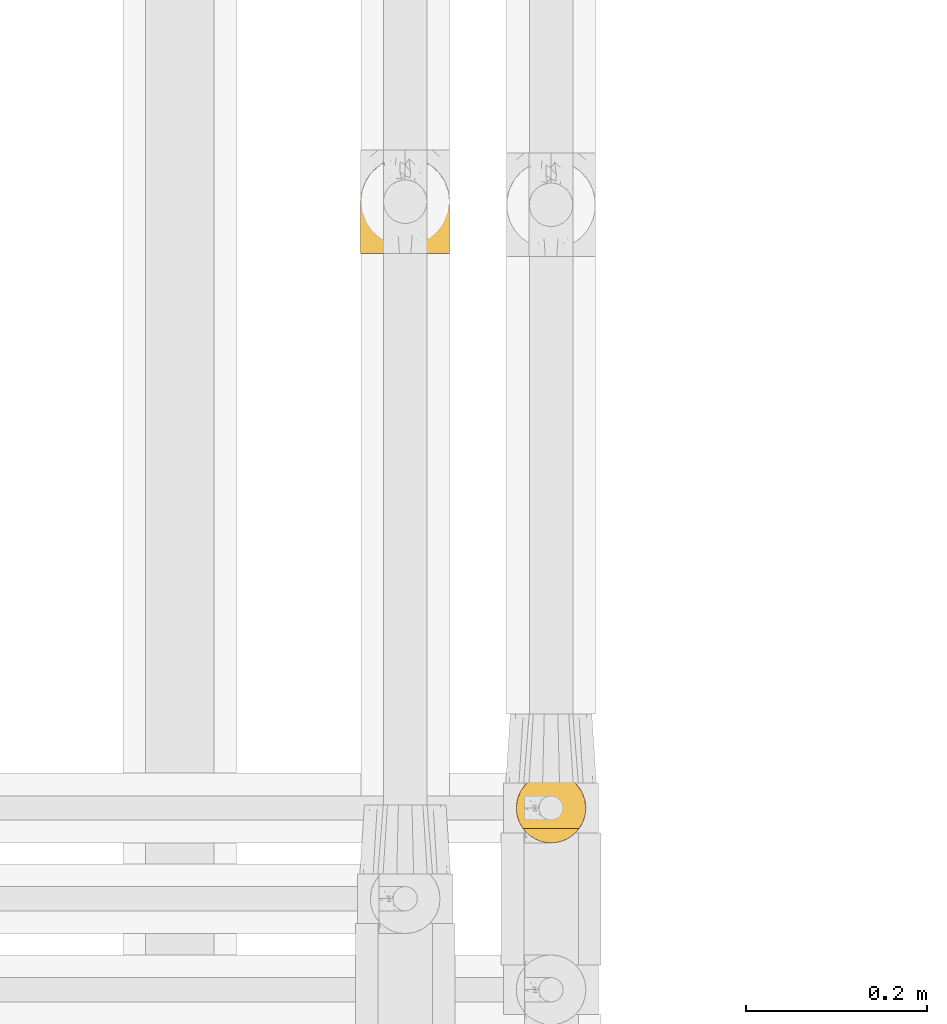
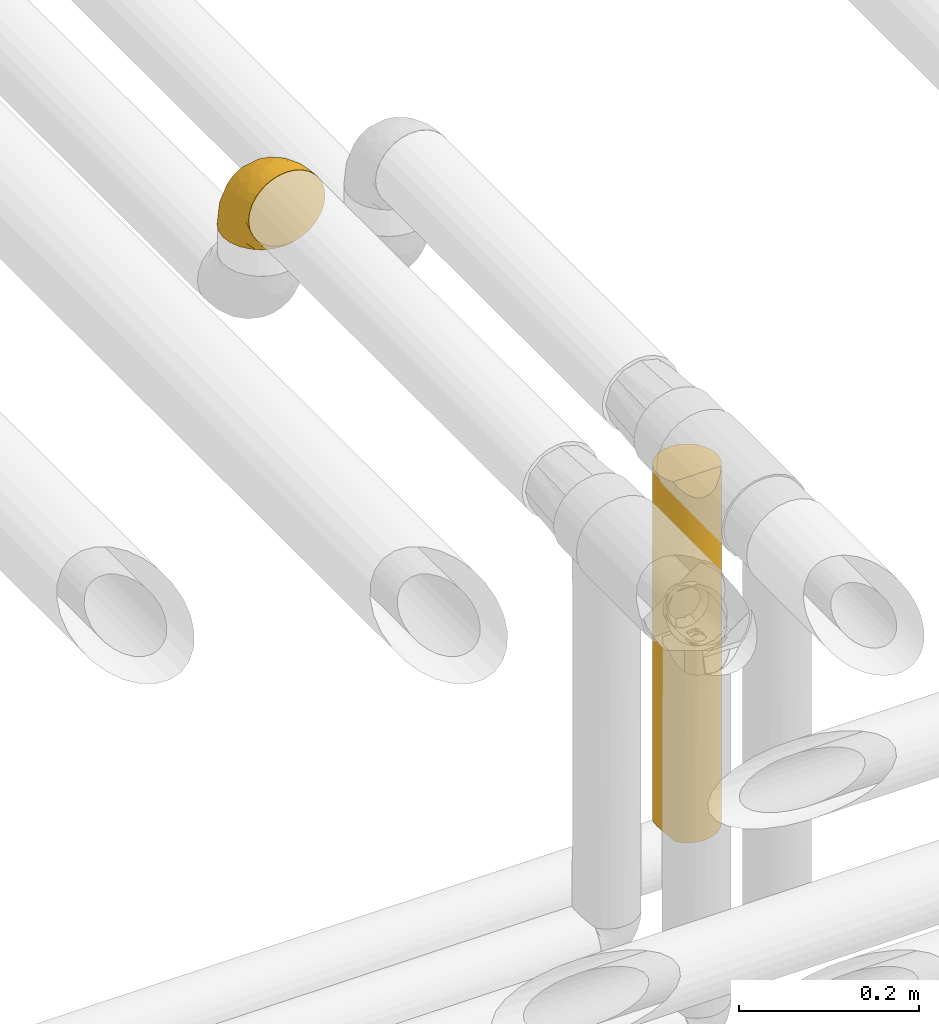
# One storey, part 345 of 827: 2 coverings.
"""IFC2X3 building model written with IfcOpenShell, lengths in millimetres."""

from ifc_helpers import new_model, entity, si_unit, converted_unit, derived_unit, direction, frame, origin, place, context, subcontext, project, spatial, faceted_brep, element, save


model = new_model("IFC2X3")

# Units and contexts
model_context = context("Model", 3, precision=0.01, world=origin(), true_north=direction((6.12303176911189e-17, 1.0)))
body_context = subcontext(model_context, "Body", "Model", "MODEL_VIEW")
ifc_project = project(units=[si_unit("LENGTHUNIT", "METRE", prefix="MILLI"), si_unit("AREAUNIT", "SQUARE_METRE"), si_unit("VOLUMEUNIT", "CUBIC_METRE"), converted_unit("PLANEANGLEUNIT", "DEGREE", entity("IfcRatioMeasure", 0.0174532925199433), si_unit("PLANEANGLEUNIT", "RADIAN"), dimensions=[0, 0, 0, 0, 0, 0, 0]), si_unit("MASSUNIT", "GRAM", prefix="KILO"), derived_unit("MASSDENSITYUNIT", [(si_unit("MASSUNIT", "GRAM", prefix="KILO"), 1), (si_unit("LENGTHUNIT", "METRE"), -3)]), derived_unit("MOMENTOFINERTIAUNIT", [(si_unit("LENGTHUNIT", "METRE"), 4)]), si_unit("TIMEUNIT", "SECOND"), si_unit("FREQUENCYUNIT", "HERTZ"), si_unit("THERMODYNAMICTEMPERATUREUNIT", "DEGREE_CELSIUS"), derived_unit("THERMALTRANSMITTANCEUNIT", [(si_unit("MASSUNIT", "GRAM", prefix="KILO"), 1), (si_unit("THERMODYNAMICTEMPERATUREUNIT", "KELVIN"), -1), (si_unit("TIMEUNIT", "SECOND"), -3)]), derived_unit("VOLUMETRICFLOWRATEUNIT", [(si_unit("LENGTHUNIT", "METRE"), 3), (si_unit("TIMEUNIT", "SECOND"), -1)]), derived_unit("MASSFLOWRATEUNIT", [(si_unit("MASSUNIT", "GRAM", prefix="KILO"), 1), (si_unit("TIMEUNIT", "SECOND"), -1)]), derived_unit("ROTATIONALFREQUENCYUNIT", [(si_unit("TIMEUNIT", "SECOND"), -1)]), si_unit("ELECTRICCURRENTUNIT", "AMPERE"), si_unit("ELECTRICVOLTAGEUNIT", "VOLT"), si_unit("POWERUNIT", "WATT"), si_unit("FORCEUNIT", "NEWTON", prefix="KILO"), si_unit("ILLUMINANCEUNIT", "LUX"), si_unit("LUMINOUSFLUXUNIT", "LUMEN"), si_unit("LUMINOUSINTENSITYUNIT", "CANDELA"), derived_unit("USERDEFINED", [(si_unit("MASSUNIT", "GRAM", prefix="KILO"), -1), (si_unit("LENGTHUNIT", "METRE"), -2), (si_unit("TIMEUNIT", "SECOND"), 3), (si_unit("LUMINOUSFLUXUNIT", "LUMEN"), 1)]), derived_unit("LINEARVELOCITYUNIT", [(si_unit("LENGTHUNIT", "METRE"), 1), (si_unit("TIMEUNIT", "SECOND"), -1)]), si_unit("PRESSUREUNIT", "PASCAL"), derived_unit("USERDEFINED", [(si_unit("LENGTHUNIT", "METRE"), -2), (si_unit("MASSUNIT", "GRAM", prefix="KILO"), 1), (si_unit("TIMEUNIT", "SECOND"), -2)]), derived_unit("LINEARFORCEUNIT", [(si_unit("MASSUNIT", "GRAM", prefix="KILO"), 1), (si_unit("LENGTHUNIT", "METRE"), 1), (si_unit("TIMEUNIT", "SECOND"), -2), (si_unit("LENGTHUNIT", "METRE"), -1)]), derived_unit("PLANARFORCEUNIT", [(si_unit("MASSUNIT", "GRAM", prefix="KILO"), 1), (si_unit("LENGTHUNIT", "METRE"), 1), (si_unit("TIMEUNIT", "SECOND"), -2), (si_unit("LENGTHUNIT", "METRE"), -2)])], contexts=[model_context])

# Site, building, storey
site_placement = place(None, origin())
site = spatial("IfcSite", under=ifc_project, at=site_placement, CompositionType="ELEMENT")
building_placement = place(site_placement, origin())
building = spatial("IfcBuilding", under=site, at=building_placement, CompositionType="ELEMENT")
storey_placement = place(building_placement, frame((0.0, 0.0, 28200.0)))
storey = spatial("IfcBuildingStorey", under=building, at=storey_placement, Name="08", CompositionType="ELEMENT", Elevation=28200.0)

# Coverings
covering_1_placement = place(storey_placement, frame((36417.97, 16200.34, 3491.4)))
element("IfcCovering", 1, at=covering_1_placement, inside=storey, Name=":ADSK_", ObjectType=":ADSK_", PredefinedType="INSULATION", context=body_context, shape_type="Brep", body=[
    faceted_brep([(99.9, 1.6, 58.6), (98.66, 1.6, 69.54), (95.02, 1.6, 79.93), (89.17, 1.6, 89.25), (81.38, 1.6, 97.03), (72.06, 1.6, 102.88), (61.68, 1.6, 106.51), (50.75, 1.6, 107.75), (39.8, 1.6, 106.51), (29.41, 1.6, 102.87), (20.09, 1.6, 97.02), (12.31, 1.6, 89.23), (6.46, 1.6, 79.91), (2.83, 1.6, 69.53), (1.6, 1.6, 58.6), (2.24, 1.6, 52.89), (2.83, 1.6, 47.65), (4.65, 1.6, 42.46), (6.47, 1.6, 37.26), (12.32, 1.6, 27.94), (20.11, 1.6, 20.16), (29.43, 1.6, 14.31), (39.81, 1.6, 10.68), (50.75, 1.6, 9.45), (61.69, 1.6, 10.68), (72.08, 1.6, 14.32), (81.4, 1.6, 20.17), (89.18, 1.6, 27.96), (95.03, 1.6, 37.28), (96.85, 1.6, 42.47), (98.66, 1.6, 47.66), (99.25, 1.6, 52.89), (99.57, 1.6, 55.75), (38.02, 11.12, 1.6), (26.17, 16.03, 1.6), (21.08, 19.94, 1.6), (15.99, 23.84, 1.6), (12.09, 28.93, 1.6), (8.18, 34.02, 1.6), (5.73, 39.95, 1.6), (3.27, 45.87, 1.6), (2.35, 52.86, 1.6), (1.97, 55.73, 1.6), (1.6, 58.6, 1.6), (3.27, 71.32, 1.6), (8.18, 83.17, 1.6), (15.99, 93.35, 1.6), (26.17, 101.16, 1.6), (38.02, 106.07, 1.6), (50.75, 107.75, 1.6), (63.47, 106.07, 1.6), (75.32, 101.16, 1.6), (85.5, 93.35, 1.6), (93.31, 83.17, 1.6), (98.22, 71.32, 1.6), (99.9, 58.6, 1.6), (99.14, 52.86, 1.6), (98.22, 45.87, 1.6), (95.77, 39.95, 1.6), (93.31, 34.02, 1.6), (89.4, 28.93, 1.6), (85.5, 23.84, 1.6), (80.41, 19.94, 1.6), (75.32, 16.03, 1.6), (63.47, 11.12, 1.6), (50.75, 9.45, 1.6), (59.31, 81.82, 69.96), (73.08, 84.02, 59.59), (63.72, 93.05, 51.96), (50.75, 102.55, 34.4), (58.64, 104.83, 23.37), (50.75, 105.83, 13.68), (76.74, 91.87, 41.52), (67.68, 101.74, 26.26), (78.92, 97.07, 20.18), (94.31, 38.45, 72.33), (98.76, 22.17, 65.88), (98.4, 42.04, 57.55), (94.57, 77.69, 23.76), (89.91, 75.76, 46.5), (96.32, 62.11, 46.57), (98.79, 66.08, 21.17), (99.9, 54.26, 23.41), (99.9, 55.35, 17.92), (99.9, 56.44, 12.43), (99.9, 56.98, 9.72), (99.9, 57.52, 7.01), (87.31, 87.84, 26.77), (95.61, 19.41, 76.59), (60.43, 48.89, 95.55), (65.24, 26.34, 102.57), (72.87, 44.55, 92.89), (99.9, 23.41, 54.26), (99.9, 28.03, 51.17), (99.9, 32.65, 48.08), (99.9, 37.28, 44.99), (99.9, 41.9, 41.9), (90.65, 20.6, 85.16), (63.14, 63.36, 85.97), (91.89, 62.21, 59.58), (75.25, 19.94, 99.5), (50.75, 13.68, 105.83), (82.18, 80.85, 53.59), (85.08, 66.53, 67.0), (76.93, 71.06, 71.56), (50.75, 63.99, 87.47), (50.75, 75.73, 75.73), (83.02, 26.77, 92.24), (99.9, 4.31, 58.06), (99.9, 7.01, 57.52), (99.9, 12.43, 56.44), (99.9, 17.92, 55.35), (87.13, 43.43, 81.33), (80.85, 56.23, 80.35), (99.17, 54.97, 39.44), (50.75, 34.4, 102.55), (99.9, 44.99, 37.28), (99.9, 48.08, 32.65), (99.9, 51.17, 28.03), (50.75, 87.47, 63.99), (67.61, 74.55, 74.55), (72.25, 60.86, 83.62), (50.75, 49.19, 95.01), (50.75, 95.01, 49.19), (98.69, 10.27, 46.96), (99.01, 48.79, 8.77), (98.79, 45.16, 18.28), (98.29, 44.99, 11.68), (68.51, 6.17, 11.79), (76.82, 7.65, 15.69), (98.54, 21.59, 42.49), (99.3, 19.96, 47.41), (83.57, 21.0, 7.94), (89.47, 27.2, 9.27), (75.76, 14.83, 7.98), (84.86, 19.7, 13.4), (75.89, 10.93, 13.04), (64.77, 9.63, 7.36), (90.83, 19.97, 23.46), (94.62, 21.13, 30.46), (90.37, 14.14, 26.54), (91.18, 30.2, 6.76), (88.65, 8.12, 26.46), (84.11, 9.93, 20.77), (91.75, 24.62, 20.68), (96.86, 11.87, 40.26), (50.75, 7.15, 7.15), (58.97, 5.32, 9.28), (98.37, 26.68, 38.78), (83.91, 13.92, 18.27), (97.52, 30.67, 31.78), (95.55, 36.65, 12.75), (98.76, 42.89, 22.96), (95.26, 34.04, 17.55), (98.04, 36.6, 27.63), (90.65, 26.41, 15.23), (93.51, 10.07, 33.25), (94.16, 15.83, 32.43), (99.1, 41.99, 27.9), (25.73, 14.83, 7.97), (10.84, 26.4, 15.22), (17.92, 21.01, 7.93), (16.64, 19.71, 13.38), (30.44, 5.72, 13.12), (2.95, 21.6, 42.49), (2.19, 19.96, 47.4), (1.6, 28.03, 51.17), (4.63, 11.87, 40.24), (17.39, 9.93, 20.76), (1.6, 58.06, 4.31), (1.6, 56.44, 12.43), (1.6, 57.52, 7.01), (12.86, 8.13, 26.44), (11.13, 14.15, 26.52), (3.2, 44.99, 11.68), (5.94, 36.65, 12.75), (12.02, 27.21, 9.27), (6.23, 34.04, 17.55), (10.31, 30.2, 6.76), (8.0, 10.06, 33.21), (7.34, 15.83, 32.41), (2.48, 48.79, 8.77), (2.73, 42.89, 22.96), (2.64, 45.38, 18.48), (1.6, 12.43, 56.44), (2.8, 10.28, 46.95), (36.71, 9.64, 7.36), (1.6, 55.35, 17.92), (1.6, 54.26, 23.41), (38.59, 6.05, 9.85), (1.6, 7.01, 57.52), (1.6, 9.72, 56.98), (1.6, 32.65, 48.08), (3.12, 26.68, 38.78), (17.59, 13.92, 18.25), (1.6, 37.28, 44.99), (3.98, 30.66, 31.74), (6.87, 21.14, 30.45), (3.45, 36.59, 27.63), (9.76, 24.6, 20.65), (1.6, 17.92, 55.35), (1.6, 23.41, 54.26), (25.62, 10.93, 13.03), (10.67, 19.97, 23.44), (2.39, 41.99, 27.9), (1.6, 48.08, 32.65), (1.6, 51.17, 28.03), (1.6, 44.99, 37.28), (1.6, 41.9, 41.9), (2.4, 55.26, 39.74), (42.85, 104.83, 23.37), (14.18, 87.84, 26.77), (11.56, 75.91, 46.18), (19.27, 80.84, 53.54), (24.75, 91.87, 41.53), (28.37, 83.98, 59.61), (5.95, 19.16, 76.79), (2.79, 22.37, 66.11), (2.71, 66.08, 21.17), (37.78, 93.05, 51.96), (33.81, 101.74, 26.26), (22.57, 97.07, 20.18), (6.92, 77.69, 23.76), (28.61, 44.55, 92.88), (36.24, 26.34, 102.57), (41.05, 48.9, 95.54), (24.55, 70.99, 71.63), (33.88, 74.55, 74.55), (7.11, 37.8, 72.51), (38.38, 63.4, 85.95), (42.18, 81.82, 69.96), (18.46, 26.77, 92.23), (10.84, 20.6, 85.15), (20.69, 56.15, 80.45), (29.27, 60.85, 83.65), (3.1, 42.06, 57.57), (9.18, 57.03, 63.68), (26.23, 19.94, 99.49), (14.34, 43.59, 81.23), (5.46, 62.61, 47.07), (16.39, 66.52, 66.99)], [[[0, 1, 2, 3, 4, 5, 6, 7, 8, 9, 10, 11, 12, 13, 14, 15, 16, 17, 18, 19, 20, 21, 22, 23, 24, 25, 26, 27, 28, 29, 30, 31, 32]], [[33, 34, 35, 36, 37, 38, 39, 40, 41, 42, 43, 44, 45, 46, 47, 48, 49, 50, 51, 52, 53, 54, 55, 56, 57, 58, 59, 60, 61, 62, 63, 64, 65]], [[66, 67, 68]], [[69, 70, 71]], [[68, 72, 73]], [[73, 72, 74]], [[75, 76, 77]], [[78, 79, 80]], [[51, 50, 73]], [[81, 82, 83, 84, 85, 86, 55]], [[52, 87, 53]], [[74, 52, 51]], [[2, 1, 88]], [[89, 90, 91]], [[77, 92, 93, 94, 95, 96]], [[55, 54, 81]], [[78, 53, 87]], [[5, 90, 6]], [[88, 76, 75]], [[97, 3, 2]], [[89, 91, 98]], [[99, 80, 79]], [[90, 5, 100]], [[74, 87, 52]], [[100, 5, 4]], [[90, 101, 6]], [[79, 102, 103]], [[102, 67, 104]], [[105, 98, 106]], [[107, 4, 3]], [[76, 0, 108, 109, 110, 111, 92]], [[107, 112, 113]], [[114, 77, 96]], [[89, 115, 90]], [[114, 96, 116, 117, 118, 82]], [[75, 97, 88]], [[119, 66, 68]], [[50, 71, 70]], [[100, 91, 90]], [[99, 77, 80]], [[102, 104, 103]], [[97, 107, 3]], [[80, 81, 78]], [[107, 97, 112]], [[68, 73, 70]], [[66, 98, 120]], [[78, 81, 54]], [[114, 81, 80]], [[53, 78, 54]], [[78, 87, 79]], [[102, 87, 72]], [[79, 103, 99]], [[4, 107, 100]], [[91, 100, 107]], [[88, 97, 2]], [[112, 97, 75]], [[99, 112, 75]], [[103, 104, 113]], [[91, 121, 98]], [[89, 105, 122, 115]], [[101, 90, 115]], [[101, 7, 6]], [[88, 1, 76]], [[0, 76, 1]], [[92, 77, 76]], [[73, 74, 51]], [[87, 74, 72]], [[81, 114, 82]], [[77, 114, 80]], [[87, 102, 79]], [[67, 102, 72]], [[68, 67, 72]], [[67, 120, 104]], [[120, 121, 104]], [[104, 121, 113]], [[121, 120, 98]], [[91, 107, 113]], [[91, 113, 121]], [[103, 113, 112]], [[66, 119, 106]], [[105, 89, 98]], [[68, 69, 123, 119]], [[98, 66, 106]], [[66, 120, 67]], [[50, 49, 71]], [[50, 70, 73]], [[112, 99, 103]], [[77, 99, 75]], [[69, 68, 70]], [[29, 124, 110]], [[84, 83, 125]], [[126, 82, 118]], [[59, 58, 127]], [[25, 128, 129]], [[130, 93, 131]], [[132, 62, 133]], [[134, 135, 136]], [[137, 65, 64]], [[64, 134, 137]], [[138, 139, 140]], [[111, 110, 124, 92]], [[134, 136, 137]], [[134, 64, 63]], [[141, 61, 60]], [[125, 58, 57]], [[142, 143, 140]], [[142, 26, 143]], [[127, 83, 82]], [[28, 124, 29]], [[108, 0, 32, 31, 30, 110, 109]], [[30, 29, 110]], [[135, 144, 138]], [[28, 145, 124]], [[57, 56, 55, 86, 85, 84]], [[146, 147, 23]], [[24, 23, 147]], [[25, 143, 26]], [[95, 94, 148]], [[24, 128, 25]], [[149, 138, 143]], [[124, 145, 131]], [[127, 58, 125]], [[150, 148, 139]], [[127, 126, 151]], [[151, 59, 127]], [[152, 151, 126]], [[153, 154, 155]], [[153, 133, 141]], [[145, 28, 27]], [[142, 156, 27]], [[157, 148, 130]], [[61, 133, 62]], [[134, 132, 135]], [[147, 128, 24]], [[65, 137, 146]], [[146, 137, 147]], [[128, 137, 136]], [[137, 128, 147]], [[128, 136, 129]], [[149, 129, 136]], [[25, 129, 143]], [[158, 152, 117]], [[152, 118, 117]], [[153, 151, 152]], [[158, 116, 154]], [[144, 150, 138]], [[153, 152, 158]], [[133, 153, 155]], [[133, 155, 132]], [[60, 151, 141]], [[135, 132, 155]], [[134, 63, 132]], [[144, 135, 155]], [[135, 138, 149]], [[155, 154, 144]], [[150, 154, 96]], [[154, 150, 144]], [[148, 94, 130]], [[82, 126, 127]], [[118, 152, 126]], [[150, 96, 95]], [[139, 148, 157]], [[150, 95, 148]], [[93, 92, 131]], [[130, 145, 156]], [[130, 94, 93]], [[84, 125, 57]], [[127, 125, 83]], [[140, 139, 157]], [[150, 139, 138]], [[140, 157, 142]], [[138, 140, 143]], [[156, 142, 157]], [[27, 26, 142]], [[130, 156, 157]], [[145, 27, 156]], [[132, 63, 62]], [[124, 131, 92]], [[130, 131, 145]], [[129, 149, 143]], [[135, 149, 136]], [[141, 133, 61]], [[60, 59, 151]], [[141, 151, 153]], [[116, 96, 154]], [[153, 158, 154]], [[158, 117, 116]], [[34, 33, 159]], [[160, 161, 162]], [[22, 21, 163]], [[164, 165, 166]], [[19, 18, 167]], [[168, 21, 20]], [[169, 43, 42, 41, 40, 170, 171]], [[172, 173, 168]], [[174, 38, 175]], [[176, 177, 178]], [[179, 164, 180]], [[40, 181, 170]], [[182, 183, 175]], [[17, 184, 185]], [[65, 146, 186]], [[187, 174, 188]], [[23, 22, 189]], [[174, 39, 38]], [[15, 14, 190, 191, 184, 16]], [[181, 40, 39]], [[192, 193, 164]], [[194, 163, 168]], [[33, 186, 159]], [[180, 173, 172]], [[195, 196, 193]], [[18, 185, 167]], [[173, 180, 197]], [[198, 199, 196]], [[200, 201, 185, 184]], [[184, 17, 16]], [[18, 17, 185]], [[202, 159, 186]], [[194, 168, 203]], [[189, 163, 202]], [[204, 205, 182]], [[187, 181, 174]], [[160, 177, 176]], [[206, 183, 182]], [[206, 182, 205]], [[201, 165, 185]], [[165, 164, 167]], [[172, 179, 180]], [[202, 194, 162]], [[176, 161, 160]], [[65, 186, 33]], [[163, 189, 22]], [[175, 177, 182]], [[174, 183, 188]], [[177, 198, 204]], [[199, 160, 162]], [[198, 207, 204]], [[175, 38, 37]], [[198, 177, 160]], [[178, 177, 175]], [[176, 35, 161]], [[34, 159, 161]], [[162, 161, 159]], [[202, 162, 159]], [[199, 162, 203]], [[196, 199, 203]], [[198, 160, 199]], [[193, 197, 180]], [[208, 198, 196]], [[188, 183, 206]], [[175, 183, 174]], [[193, 192, 195]], [[195, 208, 196]], [[197, 196, 203]], [[180, 164, 193]], [[168, 163, 21]], [[166, 165, 201]], [[166, 192, 164]], [[189, 202, 186]], [[186, 146, 189]], [[23, 189, 146]], [[174, 181, 39]], [[170, 181, 187]], [[196, 197, 193]], [[173, 203, 168]], [[203, 173, 197]], [[172, 168, 20]], [[20, 19, 172]], [[179, 172, 19]], [[19, 167, 179]], [[164, 179, 167]], [[35, 176, 36]], [[35, 34, 161]], [[185, 165, 167]], [[162, 194, 203]], [[163, 194, 202]], [[176, 178, 36]], [[37, 36, 178]], [[175, 37, 178]], [[177, 204, 182]], [[207, 198, 208]], [[207, 205, 204]], [[209, 188, 206, 205, 207, 208]], [[48, 210, 71]], [[211, 212, 213]], [[214, 213, 215]], [[216, 217, 13]], [[218, 43, 169, 171, 170, 187, 188]], [[219, 220, 214]], [[47, 46, 221]], [[210, 48, 220]], [[211, 222, 212]], [[222, 45, 44]], [[221, 220, 47]], [[47, 220, 48]], [[221, 211, 214]], [[223, 224, 225]], [[211, 46, 45]], [[226, 227, 215]], [[43, 218, 44]], [[217, 216, 228]], [[227, 229, 230]], [[14, 13, 217]], [[224, 9, 8]], [[10, 231, 11]], [[11, 232, 12]], [[233, 223, 234]], [[235, 208, 195, 192, 166, 201]], [[236, 235, 228]], [[222, 44, 218]], [[106, 230, 229]], [[224, 237, 9]], [[232, 238, 228]], [[9, 237, 10]], [[115, 224, 101]], [[239, 235, 236]], [[232, 11, 231]], [[223, 231, 237]], [[224, 8, 101]], [[223, 229, 234]], [[225, 115, 122, 105]], [[216, 12, 232]], [[209, 235, 239]], [[210, 219, 69]], [[219, 214, 215]], [[230, 119, 219]], [[209, 218, 188]], [[239, 212, 222]], [[239, 222, 218]], [[45, 222, 211]], [[236, 212, 239]], [[213, 212, 240]], [[223, 237, 224]], [[231, 10, 237]], [[238, 232, 231]], [[216, 232, 228]], [[233, 231, 223]], [[236, 238, 240]], [[115, 225, 224]], [[234, 229, 227]], [[8, 7, 101]], [[235, 209, 208]], [[218, 209, 239]], [[217, 228, 235]], [[13, 12, 216]], [[235, 201, 217]], [[217, 201, 200, 184, 191, 190, 14]], [[211, 221, 46]], [[220, 221, 214]], [[71, 210, 69]], [[71, 49, 48]], [[219, 210, 220]], [[226, 215, 213]], [[211, 213, 214]], [[226, 213, 240]], [[215, 227, 230]], [[233, 240, 238]], [[234, 227, 226]], [[233, 234, 226]], [[229, 223, 225]], [[240, 233, 226]], [[233, 238, 231]], [[225, 105, 229]], [[229, 105, 106]], [[106, 119, 230]], [[123, 69, 219, 119]], [[215, 230, 219]], [[238, 236, 228]], [[212, 236, 240]]]),
])
covering_2_placement = place(storey_placement, frame((36589.65, 15550.04, 3027.5)))
element("IfcCovering", 2, at=covering_2_placement, inside=storey, Name=":ADSK_", ObjectType=":ADSK_", PredefinedType="INSULATION", context=body_context, shape_type="Brep", body=[
    faceted_brep([(31.79, 2.48, 1.6), (23.98, 5.09, 1.6), (16.91, 9.31, 1.6), (10.9, 14.94, 1.6), (10.9, 65.05, 1.6), (16.91, 70.68, 1.6), (23.98, 74.9, 1.6), (31.79, 77.51, 1.6), (40.0, 78.4, 1.6), (49.93, 77.09, 1.6), (59.2, 73.25, 1.6), (67.15, 67.15, 1.6), (73.25, 59.2, 1.6), (77.09, 49.93, 1.6), (78.4, 40.0, 1.6), (77.09, 30.06, 1.6), (73.25, 20.8, 1.6), (67.15, 12.84, 1.6), (59.2, 6.74, 1.6), (49.93, 2.9, 1.6), (40.0, 1.6, 1.6), (6.74, 59.2, 490.0), (2.9, 49.93, 490.0), (1.6, 40.0, 490.0), (2.45, 31.93, 490.0), (4.98, 24.24, 490.0), (9.06, 17.25, 490.0), (70.93, 17.25, 490.0), (75.01, 24.24, 490.0), (77.54, 31.93, 490.0), (78.4, 40.0, 490.0), (77.09, 49.93, 490.0), (73.25, 59.2, 490.0), (67.15, 67.15, 490.0), (59.2, 73.25, 490.0), (49.93, 77.09, 490.0), (40.0, 78.4, 490.0), (30.06, 77.09, 490.0), (20.8, 73.25, 490.0), (12.84, 67.15, 490.0), (78.4, 40.0, 273.62), (76.48, 28.02, 255.92), (40.0, 1.6, 251.27), (47.46, 2.33, 209.58), (45.97, 2.06, 468.31), (69.27, 15.14, 243.58), (73.48, 21.19, 294.68), (62.33, 8.76, 227.69), (67.02, 12.71, 483.52), (62.45, 8.84, 477.99), (51.79, 3.45, 470.29), (54.76, 4.55, 223.03), (57.33, 5.73, 473.55), (40.0, 1.6, 467.64), (6.04, 22.05, 259.03), (19.86, 7.3, 235.42), (31.0, 2.66, 242.84), (10.73, 15.13, 251.9), (17.54, 8.84, 477.99), (12.97, 12.71, 483.52), (22.66, 5.73, 473.55), (34.02, 2.06, 468.31), (2.97, 29.81, 243.75), (4.0, 26.63, 8.5), (28.2, 3.45, 470.29), (6.92, 20.48, 5.57), (1.6, 40.0, 250.45), (2.2, 33.21, 10.29), (1.6, 40.0, 227.27), (1.6, 40.0, 10.9), (2.97, 50.18, 239.69), (8.89, 62.51, 250.15), (5.35, 56.56, 302.34), (16.62, 70.46, 267.16), (2.2, 46.78, 10.29), (4.0, 53.36, 8.5), (6.92, 59.51, 5.57), (27.82, 76.41, 235.98), (40.0, 78.4, 217.97), (47.54, 77.65, 208.74), (54.69, 75.47, 245.8), (77.68, 47.38, 211.45), (75.47, 54.69, 245.8), (63.37, 70.46, 245.8), (70.46, 63.37, 245.8)], [[[0, 1, 2, 3, 4, 5, 6, 7, 8, 9, 10, 11, 12, 13, 14, 15, 16, 17, 18, 19, 20]], [[21, 22, 23, 24, 25, 26, 27, 28, 29, 30, 31, 32, 33, 34, 35, 36, 37, 38, 39]], [[40, 29, 41]], [[42, 43, 44]], [[40, 15, 14]], [[40, 30, 29]], [[27, 45, 46]], [[17, 47, 18]], [[41, 28, 46]], [[27, 46, 28]], [[15, 41, 16]], [[45, 27, 48]], [[48, 47, 45]], [[47, 48, 49]], [[40, 41, 15]], [[17, 45, 47]], [[50, 44, 43]], [[50, 51, 52]], [[16, 41, 46]], [[19, 18, 51]], [[51, 47, 52]], [[43, 51, 50]], [[18, 47, 51]], [[43, 19, 51]], [[17, 16, 45]], [[43, 20, 19]], [[29, 28, 41]], [[20, 43, 42]], [[44, 53, 42]], [[52, 47, 49]], [[16, 46, 45]], [[26, 25, 54]], [[55, 1, 56]], [[57, 58, 59]], [[20, 42, 0]], [[2, 1, 55]], [[55, 56, 60]], [[42, 61, 56]], [[53, 61, 42]], [[1, 0, 56]], [[26, 54, 57]], [[54, 62, 63]], [[58, 55, 60]], [[58, 57, 55]], [[64, 60, 56]], [[57, 59, 26]], [[63, 65, 54]], [[25, 24, 62]], [[62, 54, 25]], [[62, 66, 67]], [[42, 56, 0]], [[3, 57, 65]], [[56, 61, 64]], [[67, 63, 62]], [[24, 66, 62]], [[57, 3, 2]], [[65, 57, 54]], [[67, 66, 68, 69]], [[2, 55, 57]], [[66, 24, 23]], [[70, 68, 66, 23]], [[70, 23, 22]], [[21, 71, 72]], [[71, 39, 73]], [[74, 70, 75]], [[74, 69, 68]], [[72, 75, 70]], [[76, 75, 72]], [[21, 39, 71]], [[71, 4, 76]], [[68, 70, 74]], [[73, 39, 38]], [[22, 72, 70]], [[38, 37, 77]], [[73, 5, 4]], [[76, 72, 71]], [[78, 8, 7]], [[77, 7, 6]], [[6, 73, 77]], [[78, 77, 37]], [[6, 5, 73]], [[78, 7, 77]], [[36, 78, 37]], [[77, 73, 38]], [[4, 71, 73]], [[22, 21, 72]], [[79, 35, 80]], [[31, 81, 82]], [[79, 8, 78, 36]], [[80, 35, 34]], [[79, 36, 35]], [[9, 80, 10]], [[80, 9, 79]], [[83, 11, 10]], [[83, 80, 34]], [[84, 83, 33]], [[14, 81, 40]], [[82, 32, 31]], [[31, 30, 40]], [[81, 13, 82]], [[14, 13, 81]], [[84, 12, 11]], [[82, 84, 32]], [[31, 40, 81]], [[82, 12, 84]], [[83, 84, 11]], [[33, 83, 34]], [[12, 82, 13]], [[32, 84, 33]], [[8, 79, 9]], [[80, 83, 10]], [[74, 75, 76, 4, 3, 65, 63, 67, 69]], [[52, 49, 48, 27, 26, 59, 58, 60, 64, 61, 53, 44, 50]]]),
])

save(model, "model.ifc")
